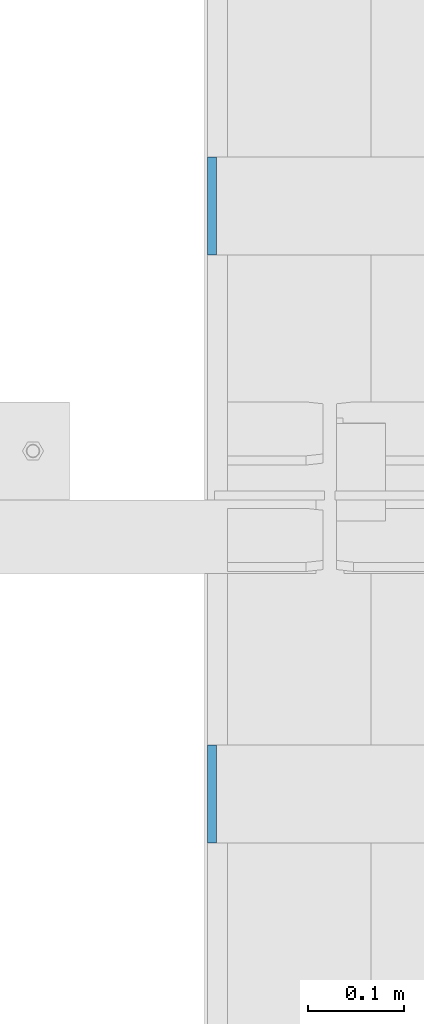
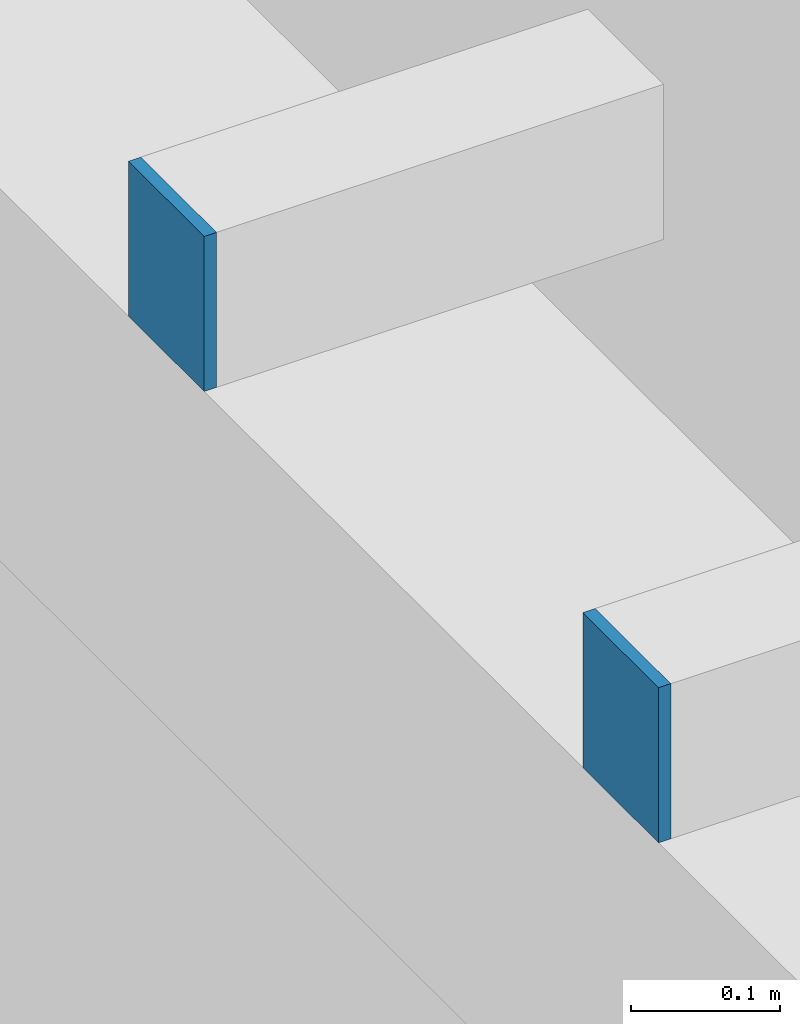
# One storey, part 459 of 1179: 2 columns, 2 elements without a shape of their own.
"""IFC2X3 building model written with IfcOpenShell, lengths in millimetres."""

from ifc_helpers import new_model, si_unit, frame, origin_with_axes, place, context, subcontext, project, spatial, faceted_brep, material, type_object, element, aggregate, save


model = new_model("IFC2X3")

# Units and contexts
model_context = context("Model", 3, precision=1e-05, world=origin_with_axes())
body_context = subcontext(model_context, "Body", "Model", "MODEL_VIEW")
ifc_project = project(units=[si_unit("LENGTHUNIT", "METRE", prefix="MILLI"), si_unit("AREAUNIT", "SQUARE_METRE"), si_unit("VOLUMEUNIT", "CUBIC_METRE"), si_unit("MASSUNIT", "GRAM", prefix="KILO"), si_unit("TIMEUNIT", "SECOND"), si_unit("PLANEANGLEUNIT", "RADIAN"), si_unit("SOLIDANGLEUNIT", "STERADIAN"), si_unit("THERMODYNAMICTEMPERATUREUNIT", "DEGREE_CELSIUS"), si_unit("LUMINOUSINTENSITYUNIT", "LUMEN")], contexts=[model_context])

# Site, building, storey
site_placement = place(None, origin_with_axes())
site = spatial("IfcSite", under=ifc_project, at=site_placement, CompositionType="ELEMENT")
building_placement = place(site_placement, origin_with_axes())
building = spatial("IfcBuilding", under=site, at=building_placement, Name="Undefined", CompositionType="ELEMENT")
storey_placement = place(building_placement, origin_with_axes())
storey = spatial("IfcBuildingStorey", under=building, at=storey_placement, Name="Undefined", CompositionType="ELEMENT", Elevation=0.0)

# Assembly, column
assembly_1_placement = place(storey_placement, origin_with_axes())
assembly_1 = element("IfcElementAssembly", 1, at=assembly_1_placement, inside=storey, Name="BEAM", AssemblyPlace="NOTDEFINED", PredefinedType="RIGID_FRAME")
ifc_material = material(Name="STEEL/A36")
column_type = type_object("IfcColumnType", PredefinedType="NOTDEFINED")
column_1_placement = place(assembly_1_placement, frame((24185.5625, 24358.6, 8013.69999998781), z_axis=(0.0, -1.0, 0.0), x_axis=(0.0, 0.0, 1.0)))
column_1 = element("IfcColumn", 2, at=column_1_placement, type_object=column_type, material=ifc_material, Name="PLATE", context=body_context, shape_type="Brep", body=[
    faceted_brep([(0.0, 4.76249999999982, -50.7999999999993), (0.0, 4.76249999999982, 50.7999999999993), (127.000000000371, 4.76249999928405, 50.8000000000002), (127.000000000371, 4.76249999928405, -50.8000000000002), (0.0, -4.76249999999982, 50.7999999999993), (127.0, -4.76250000000073, 50.7999999999993), (0.0, -4.76249999999982, -50.7999999999993), (127.0, -4.76250000000073, -50.7999999999993)], [[[0, 1, 2, 3]], [[1, 4, 5, 2]], [[4, 6, 7, 5]], [[6, 0, 3, 7]], [[5, 7, 3, 2]], [[6, 4, 1, 0]]]),
])
aggregate(assembly_1, [column_1])

assembly_2_placement = place(storey_placement, origin_with_axes())
assembly_2 = element("IfcElementAssembly", 3, at=assembly_2_placement, inside=storey, Name="BEAM", AssemblyPlace="NOTDEFINED", PredefinedType="RIGID_FRAME")
column_2_placement = place(assembly_2_placement, frame((24185.5625, 23749.0, 8013.69999998781), z_axis=(0.0, -1.0, 0.0), x_axis=(0.0, 0.0, 1.0)))
column_2 = element("IfcColumn", 4, at=column_2_placement, type_object=column_type, material=ifc_material, Name="PLATE", context=body_context, shape_type="Brep", body=[
    faceted_brep([(0.0, 4.76249999999982, -50.7999999999993), (0.0, 4.76249999999982, 50.7999999999993), (127.000000000371, 4.76249999928405, 50.8000000000002), (127.000000000371, 4.76249999928405, -50.8000000000002), (0.0, -4.76249999999982, 50.7999999999993), (127.0, -4.76250000000073, 50.7999999999993), (0.0, -4.76249999999982, -50.7999999999993), (127.0, -4.76250000000073, -50.7999999999993)], [[[0, 1, 2, 3]], [[1, 4, 5, 2]], [[4, 6, 7, 5]], [[6, 0, 3, 7]], [[5, 7, 3, 2]], [[6, 4, 1, 0]]]),
])
aggregate(assembly_2, [column_2])

save(model, "model.ifc")
